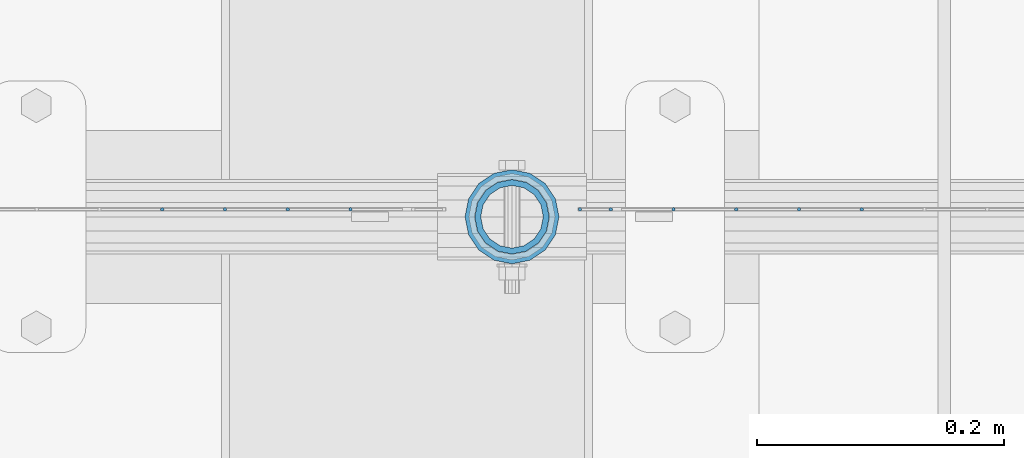
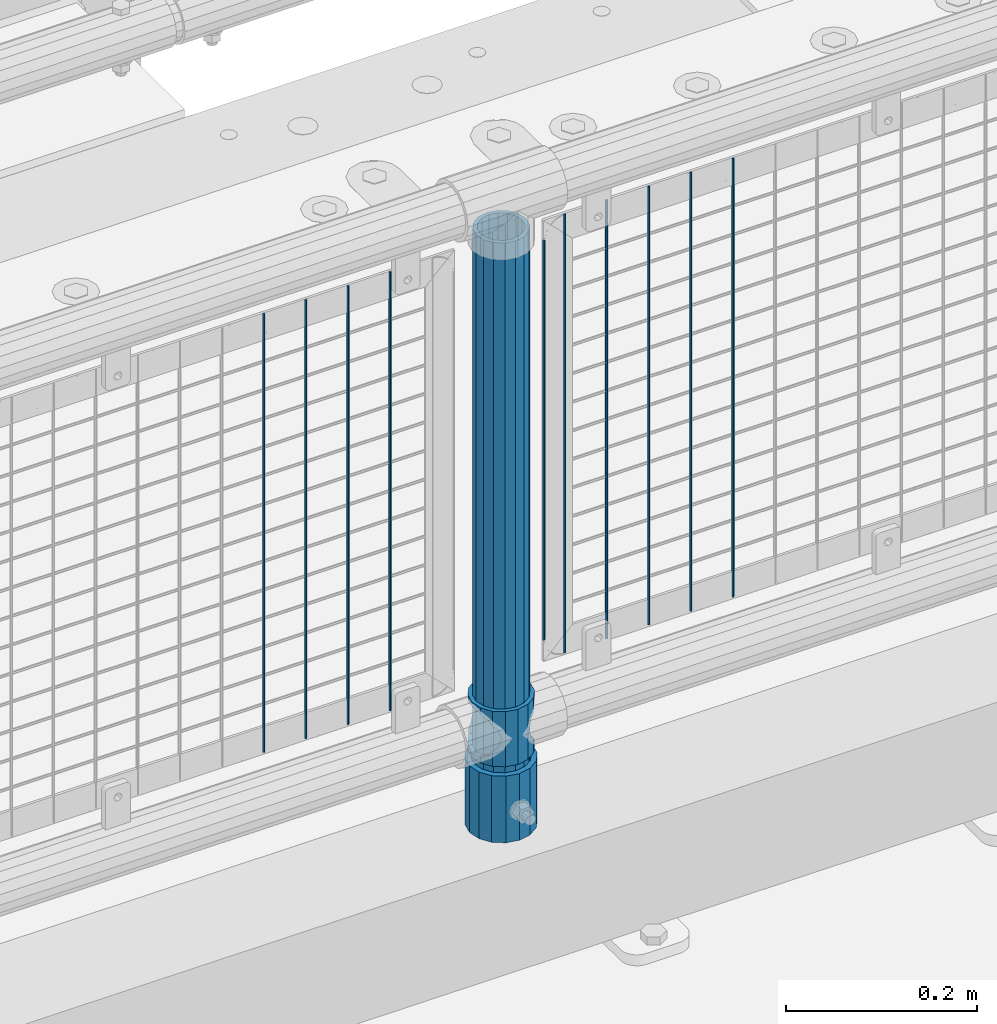
# One storey, part 95 of 270: 13 columns.
"""IFC2X3 building model written with IfcOpenShell, lengths in millimetres."""

from ifc_helpers import new_model, si_unit, frame, origin_with_axes, place, context, subcontext, project, spatial, faceted_brep, material, type_object, element, save


model = new_model("IFC2X3")

# Units and contexts
model_context = context("Model", 3, precision=1e-05, world=origin_with_axes())
body_context = subcontext(model_context, "Body", "Model", "MODEL_VIEW")
ifc_project = project(units=[si_unit("LENGTHUNIT", "METRE", prefix="MILLI"), si_unit("AREAUNIT", "SQUARE_METRE"), si_unit("VOLUMEUNIT", "CUBIC_METRE"), si_unit("MASSUNIT", "GRAM", prefix="KILO"), si_unit("TIMEUNIT", "SECOND"), si_unit("PLANEANGLEUNIT", "RADIAN"), si_unit("SOLIDANGLEUNIT", "STERADIAN"), si_unit("THERMODYNAMICTEMPERATUREUNIT", "DEGREE_CELSIUS"), si_unit("LUMINOUSINTENSITYUNIT", "LUMEN")], contexts=[model_context])

# Site, building, storey
site_placement = place(None, origin_with_axes())
site = spatial("IfcSite", under=ifc_project, at=site_placement, CompositionType="ELEMENT")
building_placement = place(site_placement, origin_with_axes())
building = spatial("IfcBuilding", under=site, at=building_placement, Name="Standard", CompositionType="ELEMENT")
storey_placement = place(building_placement, origin_with_axes())
storey = spatial("IfcBuildingStorey", under=building, at=storey_placement, Name="Undefined", CompositionType="ELEMENT", Elevation=0.0)

# Columns
ifc_material_1 = material()
column_type_1 = type_object("IfcColumnType", PredefinedType="NOTDEFINED")
column_1_placement = place(storey_placement, frame((13684.9999998042, -16335.5, 168.019999999998), z_axis=(-1.0, 0.0, 0.0), x_axis=(0.0, 0.0, 1.0)))
element("IfcColumn", 1, at=column_1_placement, inside=storey, type_object=column_type_1, material=ifc_material_1, context=body_context, shape_type="Brep", body=[
    faceted_brep([(0.0, -25.3500000000004, 0.0), (0.0, -23.4203461491616, 9.70102501045403), (760.0, -23.4203461491616, 9.70102501045403), (760.0, -25.3500000000004, 0.0), (0.0, -17.9251569030785, 17.9251569030785), (760.0, -17.9251569030785, 17.9251569030785), (0.0, -9.70102501045585, 23.4203461491597), (760.0, -9.70102501045585, 23.4203461491597), (0.0, 0.0, 25.3499999999985), (760.0, 0.0, 25.3499999999985), (0.0, 9.70102501045585, 23.4203461491597), (760.0, 9.70102501045585, 23.4203461491597), (0.0, 17.9251569030785, 17.9251569030785), (760.0, 17.9251569030785, 17.9251569030785), (0.0, 23.4203461491616, 9.70102501045403), (760.0, 23.4203461491616, 9.70102501045403), (0.0, 25.3500000000004, 0.0), (760.0, 25.3500000000004, 0.0), (0.0, 23.4203461491616, -9.70102501045403), (760.0, 23.4203461491616, -9.70102501045403), (0.0, 17.9251569030785, -17.9251569030785), (760.0, 17.9251569030785, -17.9251569030785), (0.0, 9.70102501045585, -23.4203461491597), (760.0, 9.70102501045585, -23.4203461491597), (0.0, 0.0, -25.3499999999985), (760.0, 0.0, -25.3499999999985), (0.0, -9.70102501045585, -23.4203461491597), (760.0, -9.70102501045585, -23.4203461491597), (0.0, -17.9251569030785, -17.9251569030785), (760.0, -17.9251569030785, -17.9251569030785), (0.0, -23.4203461491616, -9.70102501045403), (760.0, -23.4203461491616, -9.70102501045403), (0.0, -30.1499999999996, 0.0), (0.0, -27.8549679052157, -11.5379054858058), (760.0, -27.8549679052157, -11.5379054858058), (760.0, -30.1499999999996, 0.0), (0.0, -21.3192694527752, -21.3192694527752), (760.0, -21.3192694527752, -21.3192694527752), (0.0, -11.5379054858076, -27.8549679052157), (760.0, -11.5379054858076, -27.8549679052157), (0.0, 0.0, -30.1500000000015), (760.0, 0.0, -30.1500000000015), (0.0, 11.5379054858076, -27.8549679052157), (760.0, 11.5379054858076, -27.8549679052157), (0.0, 21.3192694527752, -21.3192694527752), (760.0, 21.3192694527752, -21.3192694527752), (0.0, 27.8549679052157, -11.5379054858058), (760.0, 27.8549679052157, -11.5379054858058), (0.0, 30.1499999999996, 0.0), (760.0, 30.1499999999996, 0.0), (0.0, 27.8549679052157, 11.5379054858058), (760.0, 27.8549679052157, 11.5379054858058), (0.0, 21.3192694527752, 21.3192694527752), (760.0, 21.3192694527752, 21.3192694527752), (0.0, 11.5379054858076, 27.8549679052157), (760.0, 11.5379054858076, 27.8549679052157), (0.0, 0.0, 30.1500000000015), (760.0, 0.0, 30.1500000000015), (0.0, -11.5379054858076, 27.8549679052157), (760.0, -11.5379054858076, 27.8549679052157), (0.0, -21.3192694527752, 21.3192694527752), (760.0, -21.3192694527752, 21.3192694527752), (0.0, -27.8549679052157, 11.5379054858058), (760.0, -27.8549679052157, 11.5379054858058)], [[[0, 1, 2, 3]], [[1, 4, 5, 2]], [[4, 6, 7, 5]], [[6, 8, 9, 7]], [[8, 10, 11, 9]], [[10, 12, 13, 11]], [[12, 14, 15, 13]], [[14, 16, 17, 15]], [[16, 18, 19, 17]], [[18, 20, 21, 19]], [[20, 22, 23, 21]], [[22, 24, 25, 23]], [[24, 26, 27, 25]], [[26, 28, 29, 27]], [[28, 30, 31, 29]], [[30, 0, 3, 31]], [[32, 33, 34, 35]], [[33, 36, 37, 34]], [[36, 38, 39, 37]], [[38, 40, 41, 39]], [[40, 42, 43, 41]], [[42, 44, 45, 43]], [[44, 46, 47, 45]], [[46, 48, 49, 47]], [[48, 50, 51, 49]], [[50, 52, 53, 51]], [[52, 54, 55, 53]], [[54, 56, 57, 55]], [[56, 58, 59, 57]], [[58, 60, 61, 59]], [[60, 62, 63, 61]], [[62, 32, 35, 63]], [[37, 39, 41, 43, 45, 47, 49, 51, 53, 55, 57, 59, 61, 63, 35, 34], [5, 7, 9, 11, 13, 15, 17, 19, 21, 23, 25, 27, 29, 31, 3, 2]], [[62, 60, 58, 56, 54, 52, 50, 48, 46, 44, 42, 40, 38, 36, 33, 32], [30, 28, 26, 24, 22, 20, 18, 16, 14, 12, 10, 8, 6, 4, 1, 0]]]),
])
column_type_2 = type_object("IfcColumnType", PredefinedType="NOTDEFINED")
column_2_placement = place(storey_placement, frame((13684.9999998042, -16335.5, 168.019999999998), z_axis=(0.0, 1.0, 0.0), x_axis=(0.0, 0.0, 1.0)))
element("IfcColumn", 2, at=column_2_placement, inside=storey, type_object=column_type_2, material=ifc_material_1, context=body_context, shape_type="Brep", body=[
    faceted_brep([(0.0, -31.75, 0.0), (0.0, -29.3331751572332, 12.1501989775916), (85.0, -29.3331751572332, 12.1501989775916), (85.0, -31.75, 0.0), (0.0, -22.4506403026717, 22.4506403026735), (85.0, -22.4506403026717, 22.4506403026735), (0.0, -12.1501989775934, 29.3331751572332), (85.0, -12.1501989775934, 29.3331751572332), (0.0, 0.0, 31.75), (85.0, 0.0, 31.75), (0.0, 12.1501989775934, 29.3331751572332), (85.0, 12.1501989775934, 29.3331751572332), (0.0, 22.4506403026717, 22.4506403026735), (85.0, 22.4506403026717, 22.4506403026735), (0.0, 29.3331751572332, 12.1501989775916), (85.0, 29.3331751572332, 12.1501989775916), (0.0, 31.75, 0.0), (85.0, 31.75, 0.0), (0.0, 29.3331751572332, -12.1501989775916), (85.0, 29.3331751572332, -12.1501989775916), (0.0, 22.4506403026717, -22.4506403026735), (85.0, 22.4506403026717, -22.4506403026735), (0.0, 12.1501989775934, -29.3331751572332), (85.0, 12.1501989775934, -29.3331751572332), (0.0, 0.0, -31.75), (85.0, 0.0, -31.75), (0.0, -12.1501989775934, -29.3331751572332), (85.0, -12.1501989775934, -29.3331751572332), (0.0, -22.4506403026717, -22.4506403026735), (85.0, -22.4506403026717, -22.4506403026735), (0.0, -29.3331751572332, -12.1501989775916), (85.0, -29.3331751572332, -12.1501989775916), (0.0, -38.0499999999993, 0.0), (0.0, -35.1536162120537, -14.561104601491), (85.0, -35.1536162120537, -14.561104601491), (85.0, -38.0499999999993, 0.0), (0.0, -26.9054130241493, -26.9054130241475), (85.0, -26.9054130241493, -26.9054130241475), (0.0, -14.5611046014928, -35.1536162120537), (85.0, -14.5611046014928, -35.1536162120537), (0.0, 0.0, -38.0499999999993), (85.0, 0.0, -38.0499999999993), (0.0, 14.5611046014928, -35.1536162120537), (85.0, 14.5611046014928, -35.1536162120537), (0.0, 26.9054130241493, -26.9054130241475), (85.0, 26.9054130241493, -26.9054130241475), (0.0, 35.1536162120537, -14.561104601491), (85.0, 35.1536162120537, -14.561104601491), (0.0, 38.0499999999993, 0.0), (85.0, 38.0499999999993, 0.0), (0.0, 35.1536162120537, 14.561104601491), (85.0, 35.1536162120537, 14.561104601491), (0.0, 26.9054130241493, 26.9054130241475), (85.0, 26.9054130241493, 26.9054130241475), (0.0, 14.5611046014928, 35.1536162120537), (85.0, 14.5611046014928, 35.1536162120537), (0.0, 0.0, 38.0499999999993), (85.0, 0.0, 38.0499999999993), (0.0, -14.5611046014928, 35.1536162120537), (85.0, -14.5611046014928, 35.1536162120537), (0.0, -26.9054130241493, 26.9054130241475), (85.0, -26.9054130241493, 26.9054130241475), (0.0, -35.1536162120537, 14.561104601491), (85.0, -35.1536162120537, 14.561104601491)], [[[0, 1, 2, 3]], [[1, 4, 5, 2]], [[4, 6, 7, 5]], [[6, 8, 9, 7]], [[8, 10, 11, 9]], [[10, 12, 13, 11]], [[12, 14, 15, 13]], [[14, 16, 17, 15]], [[16, 18, 19, 17]], [[18, 20, 21, 19]], [[20, 22, 23, 21]], [[22, 24, 25, 23]], [[24, 26, 27, 25]], [[26, 28, 29, 27]], [[28, 30, 31, 29]], [[30, 0, 3, 31]], [[32, 33, 34, 35]], [[33, 36, 37, 34]], [[36, 38, 39, 37]], [[38, 40, 41, 39]], [[40, 42, 43, 41]], [[42, 44, 45, 43]], [[44, 46, 47, 45]], [[46, 48, 49, 47]], [[48, 50, 51, 49]], [[50, 52, 53, 51]], [[52, 54, 55, 53]], [[54, 56, 57, 55]], [[56, 58, 59, 57]], [[58, 60, 61, 59]], [[60, 62, 63, 61]], [[62, 32, 35, 63]], [[37, 39, 41, 43, 45, 47, 49, 51, 53, 55, 57, 59, 61, 63, 35, 34], [5, 7, 9, 11, 13, 15, 17, 19, 21, 23, 25, 27, 29, 31, 3, 2]], [[62, 60, 58, 56, 54, 52, 50, 48, 46, 44, 42, 40, 38, 36, 33, 32], [30, 28, 26, 24, 22, 20, 18, 16, 14, 12, 10, 8, 6, 4, 1, 0]]]),
])
ifc_material_2 = material(Name="Misc_Undefined")
column_type_3 = type_object("IfcColumnType", PredefinedType="NOTDEFINED")
column_3_placement = place(storey_placement, frame((13685.0, -16335.5, 263.02), z_axis=(-1.0, 0.0, 0.0), x_axis=(0.0, 0.0, 1.0)))
element("IfcColumn", 3, at=column_3_placement, inside=storey, type_object=column_type_3, material=ifc_material_2, context=body_context, shape_type="Brep", body=[
    faceted_brep([(63.1897438117183, 11.6144421722802, -32.8397438117208), (63.1897438117183, 11.6144421722802, -28.0397438117179), (56.6106908090125, 21.4606908090118, -21.46069080901), (56.6106908090125, 21.4606908090118, -27.1226768591005), (61.9623795176767, 13.4513226476338, -32.4743655677703), (46.7644421722812, 28.0397438117179, -11.614442172282), (46.7644421722812, 28.0397438117179, -20.0882031229812), (51.5310424080071, 24.8548033587067, -24.8548033587067), (35.1500000000015, 30.35, 0.0), (35.1500000000008, 30.3500000000004, -16.6306603983612), (23.5355578277203, 28.0397438117179, -11.614442172282), (23.5355578277203, 28.0397438117179, -20.0882031229812), (18.7689575919954, 24.8548033587067, -24.8548033587067), (13.689309190989, 21.4606908090118, -21.46069080901), (13.689309190989, 21.4606908090118, -27.1226768591005), (8.33762048232484, 13.4513226476338, -32.4743655677703), (7.11025618828324, 11.6144421722802, -28.0397438117179), (7.11025618828324, 11.6144421722802, -32.8397438117208), (4.80000000000075, 0.0, -30.3499999999985), (4.80000000000075, 0.0, -35.1500000000015), (7.11025618828319, -11.6144421722802, -28.0397438117179), (7.11025618828319, -11.6144421722802, -32.8397438117172), (13.689309190989, -21.4606908090118, -21.46069080901), (13.689309190989, -21.4606908090118, -27.1226768591041), (8.33762048232484, -13.4513226476338, -32.4743655677703), (23.5355578277203, -28.0397438117179, -11.614442172282), (23.5355578277203, -28.0397438117179, -20.0882031229885), (18.7689575919954, -24.8548033587067, -24.8548033587067), (35.1500000000015, -30.35, 0.0), (35.1500000000008, -30.3500000000004, -16.6306603983721), (46.7644421722812, -28.0397438117179, -11.614442172282), (46.7644421722812, -28.0397438117179, -20.0882031229885), (51.5310424080071, -24.8548033587067, -24.8548033587067), (56.6106908090125, -21.4606908090118, -21.46069080901), (56.6106908090125, -21.4606908090118, -27.1226768591041), (61.9623795176767, -13.4513226476338, -32.4743655677703), (63.1897438117183, -11.6144421722802, -28.0397438117179), (63.1897438117183, -11.6144421722802, -32.8397438117172), (65.5000000000008, 0.0, -30.3499999999985), (65.5000000000008, 0.0, -35.1500000000015), (0.0, -28.0397438117179, -11.614442172282), (0.0, -30.3500000000004, 0.0), (0.0, -21.4606908090118, -21.46069080901), (0.0, -11.6144421722802, -28.0397438117179), (0.0, 0.0, -30.3499999999985), (0.0, 11.6144421722802, -28.0397438117179), (0.0, 21.4606908090118, -21.46069080901), (0.0, 28.0397438117179, -11.614442172282), (0.0, 30.3500000000004, 0.0), (0.0, 28.0397438117179, 11.614442172282), (23.5355578277192, 28.0397438117179, 11.614442172282), (0.0, 21.4606908090118, 21.46069080901), (13.6893091909879, 21.4606908090118, 21.46069080901), (0.0, 11.6144421722802, 28.0397438117179), (7.11025618828211, 11.6144421722802, 28.0397438117179), (0.0, 0.0, 30.3499999999985), (4.79999999999961, 0.0, 30.3499999999985), (0.0, -11.6144421722802, 28.0397438117179), (7.11025618828205, -11.6144421722802, 28.0397438117179), (0.0, -21.4606908090118, 21.46069080901), (13.6893091909879, -21.4606908090118, 21.46069080901), (0.0, -28.0397438117179, 11.614442172282), (23.5355578277191, -28.0397438117179, 11.614442172282), (0.0, -32.4743655677721, 13.4513226476338), (0.0, -35.1499999999996, 0.0), (70.2999999999993, -35.1499999999996, 0.0), (70.2999999999993, -32.4743655677721, 13.4513226476338), (0.0, 13.4513226476338, -32.4743655677703), (0.0, 24.8548033587067, -24.8548033587067), (0.0, 0.0, -35.1499999999996), (0.0, -13.4513226476338, -32.4743655677703), (0.0, -24.8548033587067, -24.8548033587067), (0.0, -24.8548033587067, 24.8548033587067), (0.0, -13.4513226476338, 32.4743655677703), (0.0, 0.0, 35.1499999999996), (0.0, 13.4513226476338, 32.4743655677703), (0.0, 24.8548033587067, 24.8548033587067), (0.0, 32.4743655677721, 13.4513226476338), (0.0, 35.1499999999996, 0.0), (0.0, 32.4743655677721, -13.4513226476338), (0.0, -32.4743655677721, -13.4513226476338), (70.2999999999993, 32.4743655677721, 13.4513226476338), (70.2999999999993, 35.1499999999996, 0.0), (70.2999999999993, 32.4743655677721, -13.4513226476338), (70.2999999999993, 24.8548033587067, -24.8548033587067), (70.2999999999993, 13.4513226476338, -32.4743655677703), (70.2999999999993, 0.0, -35.1500000000015), (70.2999999999993, -13.4513226476338, -32.4743655677703), (70.2999999999993, -24.8548033587067, -24.8548033587067), (70.2999999999993, -32.4743655677721, -13.4513226476338), (70.2999999999993, 28.0397438117179, 11.614442172282), (70.2999999999993, 21.4606908090118, 21.46069080901), (56.6106908090114, 21.4606908090118, 21.46069080901), (46.7644421722801, 28.0397438117179, 11.614442172282), (70.2999999999993, 11.6144421722802, 28.0397438117179), (63.1897438117172, 11.6144421722802, 28.0397438117179), (70.2999999999993, 0.0, 30.3499999999985), (65.4999999999997, 0.0, 30.3499999999985), (70.2999999999993, -11.6144421722802, 28.0397438117179), (63.1897438117172, -11.6144421722802, 28.0397438117179), (70.2999999999993, -21.4606908090118, 21.46069080901), (56.6106908090114, -21.4606908090118, 21.46069080901), (70.2999999999993, -28.0397438117179, 11.614442172282), (46.7644421722801, -28.0397438117179, 11.614442172282), (70.2999999999993, -11.6144421722802, -28.0397438117179), (70.2999999999993, 0.0, -30.3499999999985), (70.2999999999993, -21.4606908090118, -21.46069080901), (70.2999999999993, -28.0397438117179, -11.614442172282), (70.2999999999993, -30.3500000000004, 0.0), (70.2999999999993, 24.8548033587067, 24.8548033587067), (70.2999999999993, 13.4513226476338, 32.4743655677703), (70.2999999999993, 0.0, 35.1500000000015), (70.2999999999993, -13.4513226476338, 32.4743655677703), (70.2999999999993, -24.8548033587067, 24.8548033587067), (70.2999999999993, 30.3500000000004, 0.0), (70.2999999999993, 28.0397438117179, -11.614442172282), (70.2999999999993, 21.4606908090118, -21.46069080901), (70.2999999999993, 11.6144421722802, -28.0397438117179), (61.9623795176767, 13.4513226476338, 32.4743655677703), (51.5310424080039, 24.8548033587067, 24.8548033587067), (56.6106908090114, 21.4606908090118, 27.1226768591041), (65.4999999999997, 0.0, 35.1500000000015), (63.1897438117172, 11.6144421722802, 32.8397438117172), (63.1897438117172, -11.6144421722802, 32.8397438117172), (61.9623795176767, -13.4513226476338, 32.4743655677703), (56.6106908090114, -21.4606908090118, 27.1226768591077), (51.5310424080071, -24.8548033587067, 24.8548033587067), (18.7689575919954, -24.8548033587067, 24.8548033587067), (46.7644421722801, -28.0397438117179, 20.0882031229849), (35.1499999999996, -30.3500000000004, 16.6306603983649), (23.5355578277191, -28.0397438117179, 20.0882031229849), (8.33762048232262, -13.4513226476338, 32.4743655677703), (13.6893091909879, -21.4606908090118, 27.1226768591077), (4.79999999999961, 0.0, 35.1500000000015), (7.11025618828205, -11.6144421722802, 32.8397438117172), (7.11025618828211, 11.6144421722802, 32.8397438117172), (8.33762048232262, 13.4513226476338, 32.4743655677703), (13.6893091909879, 21.4606908090118, 27.1226768591041), (18.7689575919954, 24.8548033587067, 24.8548033587067), (23.5355578277192, 28.0397438117179, 20.0882031229885), (35.1499999999996, 30.3500000000004, 16.6306603983685), (46.7644421722801, 28.0397438117179, 20.0882031229885)], [[[0, 1, 2, 3, 4]], [[3, 2, 5, 6, 7]], [[6, 5, 8, 9]], [[9, 8, 10, 11]], [[12, 11, 10, 13, 14]], [[15, 14, 13, 16, 17]], [[17, 16, 18, 19]], [[19, 18, 20, 21]], [[21, 20, 22, 23, 24]], [[23, 22, 25, 26, 27]], [[26, 25, 28, 29]], [[29, 28, 30, 31]], [[32, 31, 30, 33, 34]], [[35, 34, 33, 36, 37]], [[37, 36, 38, 39]], [[39, 38, 1, 0]], [[40, 41, 28, 25]], [[42, 40, 25, 22]], [[43, 42, 22, 20]], [[44, 43, 20, 18]], [[45, 44, 18, 16]], [[46, 45, 16, 13]], [[47, 46, 13, 10]], [[48, 47, 10, 8]], [[49, 48, 8, 50]], [[51, 49, 50, 52]], [[53, 51, 52, 54]], [[55, 53, 54, 56]], [[57, 55, 56, 58]], [[59, 57, 58, 60]], [[61, 59, 60, 62]], [[41, 61, 62, 28]], [[63, 64, 65, 66]], [[67, 68, 12, 14, 15]], [[69, 67, 15, 17, 19]], [[24, 70, 69, 19, 21]], [[27, 71, 70, 24, 23]], [[63, 72, 73, 74, 75, 76, 77, 78, 79, 68, 67, 69, 70, 71, 80, 64], [40, 42, 43, 44, 45, 46, 47, 48, 49, 51, 53, 55, 57, 59, 61, 41]], [[78, 77, 81, 82]], [[79, 78, 82, 83]], [[68, 79, 83, 84, 7, 6, 9, 11, 12]], [[7, 84, 85, 4, 3]], [[4, 85, 86, 39, 0]], [[87, 88, 32, 34, 35]], [[86, 87, 35, 37, 39]], [[29, 31, 32, 88, 89, 80, 71, 27, 26]], [[64, 80, 89, 65]], [[90, 91, 92, 93]], [[91, 94, 95, 92]], [[94, 96, 97, 95]], [[96, 98, 99, 97]], [[98, 100, 101, 99]], [[100, 102, 103, 101]], [[104, 105, 38, 36]], [[106, 104, 36, 33]], [[107, 106, 33, 30]], [[108, 107, 30, 28]], [[102, 108, 28, 103]], [[88, 87, 86, 85, 84, 83, 82, 81, 109, 110, 111, 112, 113, 66, 65, 89], [100, 98, 96, 94, 91, 90, 114, 115, 116, 117, 105, 104, 106, 107, 108, 102]], [[118, 110, 109, 119, 120]], [[121, 111, 110, 118, 122]], [[112, 111, 121, 123, 124]], [[113, 112, 124, 125, 126]], [[127, 72, 63, 66, 113, 126, 128, 129, 130]], [[131, 73, 72, 127, 132]], [[133, 74, 73, 131, 134]], [[75, 74, 133, 135, 136]], [[76, 75, 136, 137, 138]], [[119, 109, 81, 77, 76, 138, 139, 140, 141]], [[92, 120, 119, 141, 93]], [[95, 122, 118, 120, 92]], [[97, 121, 122, 95]], [[99, 123, 121, 97]], [[101, 125, 124, 123, 99]], [[103, 128, 126, 125, 101]], [[28, 129, 128, 103]], [[62, 130, 129, 28]], [[60, 132, 127, 130, 62]], [[58, 134, 131, 132, 60]], [[56, 133, 134, 58]], [[54, 135, 133, 56]], [[52, 137, 136, 135, 54]], [[50, 139, 138, 137, 52]], [[8, 140, 139, 50]], [[93, 141, 140, 8]], [[114, 90, 93, 8]], [[115, 114, 8, 5]], [[116, 115, 5, 2]], [[117, 116, 2, 1]], [[105, 117, 1, 38]]]),
])
column_type_4 = type_object("IfcColumnType", Name="D3", PredefinedType="NOTDEFINED")
for number, where, z_axis, x_axis in (
    (4, (13968.172, -16329.5, 353.02), (-1.0, 0.0, 0.0), (0.0, 0.0, 1.0)),
    (5, (13917.379, -16329.5, 353.02), (-1.0, 0.0, 0.0), (0.0, 0.0, 1.0)),
    (6, (13866.586, -16329.5, 353.02), (-1.0, 0.0, 0.0), (0.0, 0.0, 1.0)),
    (7, (13815.793, -16329.5, 353.02), (-1.0, 0.0, 0.0), (0.0, 0.0, 1.0)),
):
    element("IfcColumn", number, at=place(storey_placement, frame(where, z_axis=z_axis, x_axis=x_axis)), inside=storey, type_object=column_type_4, material=ifc_material_2, ObjectType="D3", context=body_context, shape_type="Brep", body=[
        faceted_brep([(0.0, -1.5, 0.0), (0.0, -0.75, -1.29903810567669), (560.0, -0.75, -1.29903810567703), (560.0, -1.5, 0.0), (0.0, 0.75, -1.29903810567669), (560.0, 0.75, -1.29903810567703), (0.0, 1.5, 0.0), (560.0, 1.5, 0.0), (0.0, 0.75, 1.29903810567669), (560.0, 0.75, 1.29903810567703), (0.0, -0.75, 1.29903810567669), (560.0, -0.75, 1.29903810567703)], [[[0, 1, 2, 3]], [[1, 4, 5, 2]], [[4, 6, 7, 5]], [[6, 8, 9, 7]], [[8, 10, 11, 9]], [[10, 0, 3, 11]], [[5, 7, 9, 11, 3, 2]], [[10, 8, 6, 4, 1, 0]]]),
    ])
column_4_placement = place(storey_placement, frame((13740.0, -16329.5, 378.02), z_axis=(-1.0, 0.0, 0.0), x_axis=(0.0, 0.0, 1.0)))
element("IfcColumn", 8, at=column_4_placement, inside=storey, type_object=column_type_4, material=ifc_material_2, ObjectType="D3", context=body_context, shape_type="Brep", body=[
    faceted_brep([(0.0, -1.5, 0.0), (0.0, -0.75, -1.29903810567669), (510.0, -0.75, -1.29903810567703), (510.0, -1.5, 0.0), (0.0, 0.75, -1.29903810567669), (510.0, 0.75, -1.29903810567703), (0.0, 1.5, 0.0), (510.0, 1.5, 0.0), (0.0, 0.75, 1.29903810567669), (510.0, 0.75, 1.29903810567703), (0.0, -0.75, 1.29903810567669), (510.0, -0.75, 1.29903810567703)], [[[0, 1, 2, 3]], [[1, 4, 5, 2]], [[4, 6, 7, 5]], [[6, 8, 9, 7]], [[8, 10, 11, 9]], [[10, 0, 3, 11]], [[5, 7, 9, 11, 3, 2]], [[10, 8, 6, 4, 1, 0]]]),
])
for number, where, z_axis, x_axis in (
    (9, (13765.0, -16329.5, 353.02), (-1.0, 0.0, 0.0), (0.0, 0.0, 1.0)),
    (10, (13554.204, -16329.5, 353.02), (-1.0, 0.0, 0.0), (0.0, 0.0, 1.0)),
    (11, (13503.411, -16329.5, 353.02), (-1.0, 0.0, 0.0), (0.0, 0.0, 1.0)),
    (12, (13452.618, -16329.5, 353.02), (-1.0, 0.0, 0.0), (0.0, 0.0, 1.0)),
    (13, (13401.825, -16329.5, 353.02), (-1.0, 0.0, 0.0), (0.0, 0.0, 1.0)),
):
    element("IfcColumn", number, at=place(storey_placement, frame(where, z_axis=z_axis, x_axis=x_axis)), inside=storey, type_object=column_type_4, material=ifc_material_2, ObjectType="D3", context=body_context, shape_type="Brep", body=[
        faceted_brep([(0.0, -1.5, 0.0), (0.0, -0.75, -1.29903810567669), (560.0, -0.75, -1.29903810567703), (560.0, -1.5, 0.0), (0.0, 0.75, -1.29903810567669), (560.0, 0.75, -1.29903810567703), (0.0, 1.5, 0.0), (560.0, 1.5, 0.0), (0.0, 0.75, 1.29903810567669), (560.0, 0.75, 1.29903810567703), (0.0, -0.75, 1.29903810567669), (560.0, -0.75, 1.29903810567703)], [[[0, 1, 2, 3]], [[1, 4, 5, 2]], [[4, 6, 7, 5]], [[6, 8, 9, 7]], [[8, 10, 11, 9]], [[10, 0, 3, 11]], [[5, 7, 9, 11, 3, 2]], [[10, 8, 6, 4, 1, 0]]]),
    ])

save(model, "model.ifc")
